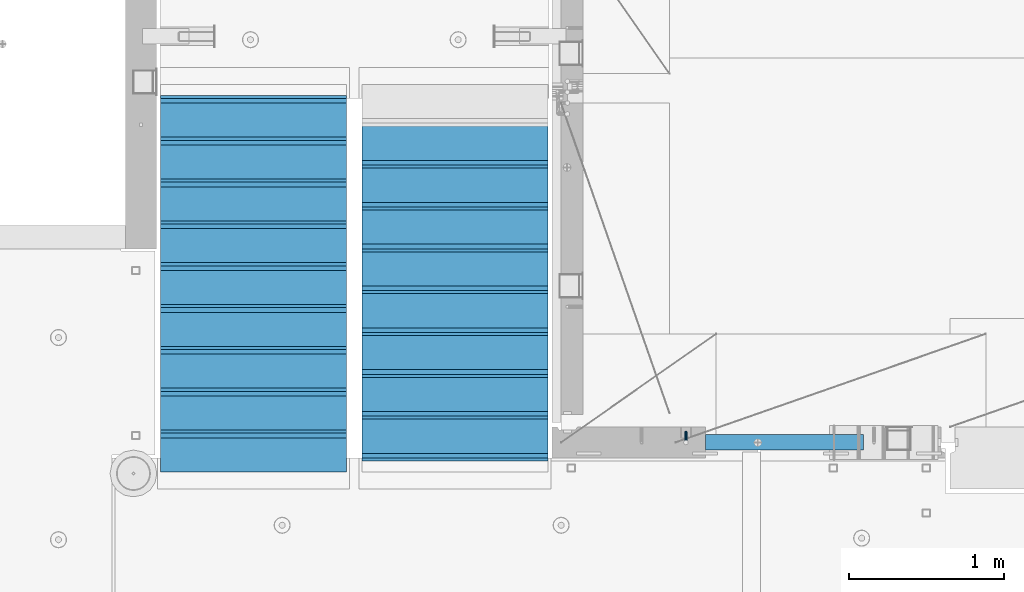
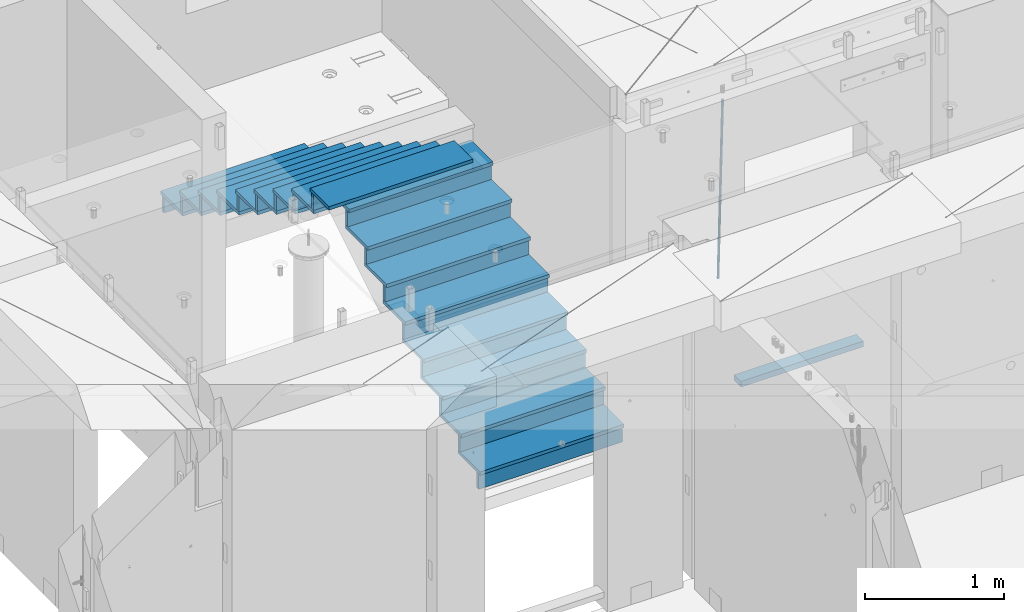
# One storey, part 103 of 325: 36 beams, 3 elements without a shape of their own.
"""IFC2X3 building model written with IfcOpenShell, lengths in millimetres."""

from ifc_helpers import new_model, si_unit, frame, origin_with_axes, place, context, subcontext, project, spatial, faceted_brep, material, type_object, element, aggregate, save


model = new_model("IFC2X3")

# Units and contexts
model_context = context("Model", 3, precision=1e-05, world=origin_with_axes())
body_context = subcontext(model_context, "Body", "Model", "MODEL_VIEW")
ifc_project = project(units=[si_unit("LENGTHUNIT", "METRE", prefix="MILLI"), si_unit("AREAUNIT", "SQUARE_METRE"), si_unit("VOLUMEUNIT", "CUBIC_METRE"), si_unit("MASSUNIT", "GRAM", prefix="KILO"), si_unit("TIMEUNIT", "SECOND"), si_unit("PLANEANGLEUNIT", "RADIAN"), si_unit("SOLIDANGLEUNIT", "STERADIAN"), si_unit("THERMODYNAMICTEMPERATUREUNIT", "DEGREE_CELSIUS"), si_unit("LUMINOUSINTENSITYUNIT", "LUMEN")], contexts=[model_context])

# Site, building, storey
site_placement = place(None, origin_with_axes())
site = spatial("IfcSite", under=ifc_project, at=site_placement, CompositionType="ELEMENT")
building_placement = place(site_placement, origin_with_axes())
building = spatial("IfcBuilding", under=site, at=building_placement, CompositionType="ELEMENT")
storey_placement = place(building_placement, origin_with_axes())
storey = spatial("IfcBuildingStorey", under=building, at=storey_placement, Name="1", CompositionType="ELEMENT", Elevation=0.0)

# Assembly, beams
assembly_1_placement = place(storey_placement, origin_with_axes())
assembly_1 = element("IfcElementAssembly", 1, at=assembly_1_placement, inside=storey, AssemblyPlace="NOTDEFINED", PredefinedType="REINFORCEMENT_UNIT")
ifc_material_1 = material()
beam_type_1 = type_object("IfcBeamType", Name="D20", PredefinedType="NOTDEFINED")
beam_1_placement = place(assembly_1_placement, frame((23075.0006866416, 17045.0000022791, 82790.0), z_axis=(0.00020576299992186, -0.999642804629538, -0.0267249099901004), x_axis=(-4.30000201928125e-08, -0.0267249099948059, 0.999642825806181)))
beam_1 = element("IfcBeam", 2, at=beam_1_placement, type_object=beam_type_1, material=ifc_material_1, Name="JM20", ObjectType="D20", context=body_context, shape_type="Brep", body=[
    faceted_brep([(0.0, -10.0, 0.0), (-4.19531716033816e-08, -7.07106781186667, -7.07106781187031), (60.4266690400545, -7.0710677960451, -7.07106780570757), (60.4266690441291, -9.99999998418934, 6.15546014159918e-09), (0.0, 0.0, -10.0), (60.426669036824, 1.58106558956206e-08, -9.99999999384454), (4.196772351861e-08, 7.07106781186303, -7.07106781186667), (60.4266690363438, 7.07106782768096, -7.07106780570757), (0.0, 10.0, 0.0), (60.4266690388904, 10.0000000158179, 6.15182216279209e-09), (4.196772351861e-08, 7.07106781185939, 7.07106781185939), (60.4266690429649, 7.07106782768096, 7.07106781802577), (0.0, 0.0, 10.0), (60.4266690461809, 1.58179318532348e-08, 10.0000000061555), (-4.19531716033816e-08, -7.07106781187031, 7.07106781185939), (60.4266690466611, -7.07106779605238, 7.07106781802213), (61.0378400410118, -7.07106779588503, -7.07106780564936), (60.991799419251, -9.99999998403655, 6.21366780251265e-09), (61.0569027789461, 1.5985278878361e-08, -9.99999999378269), (61.0378209396877, 7.07106782784831, -7.07106780564936), (60.9917724058905, 10.0000000159635, 6.21366780251265e-09), (60.9457317841297, 7.07106782781193, 7.0710678180767), (60.9266690461809, 1.59488990902901e-08, 10.0000000062028), (60.9457508854539, -7.07106779591413, 7.0710678180767), (61.6489592143771, -7.07106614513759, -7.06310863441468), (61.5568818710308, -9.9999984576425, 0.00735959856683621), (61.6870830769039, 1.71821739058942e-06, -9.99179257185824), (61.6489210170112, 7.07106947854481, -7.06310888312146), (61.556827851804, 10.0000015422847, 0.00735924683976918), (61.4647505084577, 7.07106922979438, 7.07782747982128), (61.4266266459163, 1.36643211590126e-06, 10.0065114172685), (61.464788705809, -7.07106639389531, 7.07782772852806), (176.543135720174, -7.07075579406956, -5.56673531796696), (176.451058376813, -9.99968810657447, 1.50373291501455), (176.581259582701, 0.000312069292704109, -8.49541925541052), (176.543097522794, 7.07137982961285, -5.56673556667374), (176.451004357587, 10.00031189336, 1.50373256329476), (176.35892701424, 7.07137958085514, 8.57420079627263), (176.320803151699, 0.000311717507429421, 11.5028847337162), (176.358965211621, -7.07075604281999, 8.57420104497578), (177.098753836006, -7.07075429323595, -5.55949898843028), (176.98362511232, -9.99968666800123, 1.510669025065), (177.146421932586, 0.000313595905026887, -8.48805862247536), (177.098706077581, 7.07138133041735, -5.55949936166144), (176.983557571715, 10.0003133318824, 1.51066849724157), (176.868428848029, 7.07138095712435, 8.58083651073321), (176.820760751449, 0.000313067976094317, 11.5093961447819), (176.868476606425, -7.07075466652896, 8.58083688396073), (177.654312950661, -7.07075204110879, -5.54863964998367), (177.516135294456, -9.99968450931192, 1.52107783331303), (177.711524267797, 0.000315886711177882, -8.47701274570863), (177.654255632195, 7.07138358250813, -5.54864021007961), (177.516054233929, 10.0003154905207, 1.5210770412159), (177.377876577739, 7.0713830223176, 8.59079452451624), (177.320665260588, 0.000315094497636892, 11.5191676202448), (177.377933896176, -7.07075260129932, 8.59079508461218), (299.580241614967, -7.07025777803938, -3.16539205229128), (299.442063958748, -9.99919024624614, 3.90432543100542), (299.637452932104, 0.000810149780591019, -6.09376514801625), (299.58018429653, 7.07187784557391, -3.16539261238358), (299.441982898265, 10.0008097535901, 3.90432463891557), (299.303805242045, 7.07187728538338, 10.974042122205), (299.246593924894, 0.00080935756341205, 13.9024152179336), (299.303862560482, -7.07025833822991, 10.9740426822973), (300.088882651282, -7.07025571611666, -3.15544980669438), (299.971788958996, -9.99918809853989, 3.91467979818117), (300.137357441272, 0.000812176291219657, -6.0839936725497), (300.088834180511, 7.07187990754028, -3.15545019384081), (299.971753863239, 10.0008119014747, 3.91467990454839), (299.854660170953, 7.07187951844026, 10.9848095094276), (299.806185380992, 0.000811626032373169, 13.9133533752902), (299.854708641738, -7.07025610520941, 10.9848098965813), (300.597573977022, -7.07025429077839, -3.14854421417112), (300.501599787152, -9.99918661431002, 3.92187219230618), (300.637311376035, 0.00081357714952901, -6.07720669196715), (300.597534354776, 7.07188133290401, -3.14854448120241), (300.501543752835, 10.0008133856099, 3.92187181466215), (300.40556956298, 7.07188106207104, 10.9922882211395), (300.365832163967, 0.000813194146758178, 13.9209506989318), (300.405609185211, -7.07025456160045, 10.9922884881707), (1494.60304651056, -7.06690872122999, 13.060333041718), (1494.50707232069, -9.99584104476162, 20.1307494481916), (1494.64278390956, 0.00415914670156781, 10.1316705639183), (1494.6030068883, 7.07522690244878, 13.0603327746867), (1494.50701628637, 10.004158955162, 20.1307490705476), (1494.4110420965, 7.07522663162308, 27.2011654770249), (1494.3713046975, 0.00415876370243495, 30.1298279548209), (1494.41108171875, -7.06690899205205, 27.2011657440526), (1495.1211563645, -7.06690726950183, 13.067366492749), (1495.00702625545, -9.99583964390331, 20.1375364287742), (1495.20660775043, 0.00416072652296862, 10.1393245920117), (1495.21332415029, 7.07522861253892, 13.0686179608165), (1495.13737118813, 10.0041607213934, 20.1393062718889), (1495.02324107911, 7.07522834699193, 27.2094762079141), (1494.93778969315, 0.00416035097441636, 30.1375181086514), (1494.93107329329, -7.06690753504881, 27.2082247398503), (1495.63922435709, -7.07365070849846, 13.0742491942874), (1495.5069397148, -10.00235861486, 20.1441724282631), (1495.77038591086, -0.00317370150150964, 10.1468279224828), (1495.82359171678, 7.06728286786529, 13.0767522910828), (1495.76767453534, 9.99594143344802, 20.1477123416917), (1495.63538989302, 7.0672335270865, 27.2176355756565), (1495.50422833927, -0.00324347991045215, 30.1450568474684), (1495.45102253335, -7.07370004928453, 27.2151324788683), (1517.48046966468, -7.35846502584536, 13.3649345949125), (1517.34818502239, -10.2871729322142, 20.4348578288809), (1517.61163121845, -0.287988018848409, 10.4375133231042), (1517.66483702436, 6.78246855052203, 13.3674376917079), (1517.60891984291, 9.71112711610476, 20.4383977423167), (1517.47663520063, 6.78241920973232, 27.5083209762815), (1517.34547364687, -0.288057797257352, 30.4357422480862), (1517.29226784095, -7.35851436663143, 27.5058178794898), (1518.11590717161, -7.36675126123009, 13.3733916404526), (1518.00827439407, -10.295780632965, 20.4436429663911), (1518.18994308249, -0.295529324139352, 10.4452100827657), (1518.18701289421, 6.77565927010801, 13.3743873367348), (1518.10883307132, 9.70460814510079, 20.4450510935785), (1518.00120029377, 6.77557877335857, 27.515302419517), (1517.9271643829, -0.295643163732166, 30.4434839772002), (1517.93009457119, -7.36683175797953, 27.5143067232275), (1518.75139849893, -7.36487536471395, 13.3816537936873), (1518.66841952164, -10.2938120781764, 20.4522328350286), (1518.76830418318, -0.293831718903675, 10.452712053142), (1518.7092334538, 6.77719739167878, 13.3811419616068), (1518.60878914295, 9.7060990139762, 20.4515089951637), (1518.52581016565, 6.77716230052101, 27.522088036505), (1518.50890448141, -0.293881345296541, 30.4510297770539), (1518.56797521077, -7.36491045587172, 27.5225998685855), (1618.77218426704, -7.06661321754655, 14.6790318180938), (1618.68920528975, -9.99554993101265, 21.7496108594387), (1618.78908995127, 0.0044304282637313, 11.7500900775485), (1618.73001922191, 7.07545953884255, 14.6785199860096), (1618.62957491104, 10.0043611611436, 21.748887019563), (1618.54659593375, 7.07542444768478, 28.8194660609042), (1618.52969024952, 0.00438080187086598, 31.7484078014531), (1618.58876097888, -7.06664830870795, 28.819977892992)], [[[0, 1, 2, 3]], [[1, 4, 5, 2]], [[4, 6, 7, 5]], [[6, 8, 9, 7]], [[8, 10, 11, 9]], [[10, 12, 13, 11]], [[12, 14, 15, 13]], [[14, 0, 3, 15]], [[14, 12, 10, 8, 6, 4, 1, 0]], [[3, 2, 16, 17]], [[2, 5, 18, 16]], [[5, 7, 19, 18]], [[7, 9, 20, 19]], [[9, 11, 21, 20]], [[11, 13, 22, 21]], [[13, 15, 23, 22]], [[15, 3, 17, 23]], [[17, 16, 24, 25]], [[16, 18, 26, 24]], [[18, 19, 27, 26]], [[19, 20, 28, 27]], [[20, 21, 29, 28]], [[21, 22, 30, 29]], [[22, 23, 31, 30]], [[23, 17, 25, 31]], [[25, 24, 32, 33]], [[24, 26, 34, 32]], [[26, 27, 35, 34]], [[27, 28, 36, 35]], [[28, 29, 37, 36]], [[29, 30, 38, 37]], [[30, 31, 39, 38]], [[31, 25, 33, 39]], [[33, 32, 40, 41]], [[32, 34, 42, 40]], [[34, 35, 43, 42]], [[35, 36, 44, 43]], [[36, 37, 45, 44]], [[37, 38, 46, 45]], [[38, 39, 47, 46]], [[39, 33, 41, 47]], [[41, 40, 48, 49]], [[40, 42, 50, 48]], [[42, 43, 51, 50]], [[43, 44, 52, 51]], [[44, 45, 53, 52]], [[45, 46, 54, 53]], [[46, 47, 55, 54]], [[47, 41, 49, 55]], [[49, 48, 56, 57]], [[48, 50, 58, 56]], [[50, 51, 59, 58]], [[51, 52, 60, 59]], [[52, 53, 61, 60]], [[53, 54, 62, 61]], [[54, 55, 63, 62]], [[55, 49, 57, 63]], [[57, 56, 64, 65]], [[56, 58, 66, 64]], [[58, 59, 67, 66]], [[59, 60, 68, 67]], [[60, 61, 69, 68]], [[61, 62, 70, 69]], [[62, 63, 71, 70]], [[63, 57, 65, 71]], [[65, 64, 72, 73]], [[64, 66, 74, 72]], [[66, 67, 75, 74]], [[67, 68, 76, 75]], [[68, 69, 77, 76]], [[69, 70, 78, 77]], [[70, 71, 79, 78]], [[71, 65, 73, 79]], [[73, 72, 80, 81]], [[72, 74, 82, 80]], [[74, 75, 83, 82]], [[75, 76, 84, 83]], [[76, 77, 85, 84]], [[77, 78, 86, 85]], [[78, 79, 87, 86]], [[79, 73, 81, 87]], [[81, 80, 88, 89]], [[80, 82, 90, 88]], [[82, 83, 91, 90]], [[83, 84, 92, 91]], [[84, 85, 93, 92]], [[85, 86, 94, 93]], [[86, 87, 95, 94]], [[87, 81, 89, 95]], [[89, 88, 96, 97]], [[88, 90, 98, 96]], [[90, 91, 99, 98]], [[91, 92, 100, 99]], [[92, 93, 101, 100]], [[93, 94, 102, 101]], [[94, 95, 103, 102]], [[95, 89, 97, 103]], [[97, 96, 104, 105]], [[96, 98, 106, 104]], [[98, 99, 107, 106]], [[99, 100, 108, 107]], [[100, 101, 109, 108]], [[101, 102, 110, 109]], [[102, 103, 111, 110]], [[103, 97, 105, 111]], [[105, 104, 112, 113]], [[104, 106, 114, 112]], [[106, 107, 115, 114]], [[107, 108, 116, 115]], [[108, 109, 117, 116]], [[109, 110, 118, 117]], [[110, 111, 119, 118]], [[111, 105, 113, 119]], [[113, 112, 120, 121]], [[112, 114, 122, 120]], [[114, 115, 123, 122]], [[115, 116, 124, 123]], [[116, 117, 125, 124]], [[117, 118, 126, 125]], [[118, 119, 127, 126]], [[119, 113, 121, 127]], [[121, 120, 128, 129]], [[120, 122, 130, 128]], [[122, 123, 131, 130]], [[123, 124, 132, 131]], [[124, 125, 133, 132]], [[125, 126, 134, 133]], [[126, 127, 135, 134]], [[127, 121, 129, 135]], [[130, 131, 132, 133, 134, 135, 129, 128]]]),
])
ifc_material_2 = material(Name="TIMBER/T24")
beam_type_2 = type_object("IfcBeamType", PredefinedType="NOTDEFINED")
beam_2_placement = place(assembly_1_placement, frame((23200.0006866455, 16980.0, 81880.0), z_axis=(0.0, 0.0, 1.0), x_axis=(1.0, 0.0, 0.0)))
beam_2 = element("IfcBeam", 3, at=beam_2_placement, type_object=beam_type_2, material=ifc_material_2, context=body_context, shape_type="Brep", body=[
    faceted_brep([(0.0, 50.0, -25.0), (0.0, 50.0, 25.0), (1020.0, 50.0, 25.0), (1020.0, 50.0, -25.0), (0.0, -50.0, 25.0), (1020.0, -50.0, 25.0), (0.0, -50.0, -25.0), (1020.0, -50.0, -25.0)], [[[0, 1, 2, 3]], [[1, 4, 5, 2]], [[4, 6, 7, 5]], [[6, 0, 3, 7]], [[5, 7, 3, 2]], [[6, 4, 1, 0]]]),
])
aggregate(assembly_1, [beam_1, beam_2])

assembly_2_placement = place(storey_placement, origin_with_axes())
assembly_2 = element("IfcElementAssembly", 4, at=assembly_2_placement, inside=storey, Name="E9", AssemblyPlace="NOTDEFINED", PredefinedType="NOTDEFINED")
ifc_material_3 = material(Name="Undefined/C32/40")
beam_type_3 = type_object("IfcBeamType", PredefinedType="NOTDEFINED")
beam_3_placement = place(assembly_2_placement, frame((20885.0002457424, 17024.9998138874, 84662.1), z_axis=(0.0, 1.0, 0.0), x_axis=(-1.0, 3.00000001838171e-08, 0.0)))
beam_3 = element("IfcBeam", 5, at=beam_3_placement, type_object=beam_type_3, material=ifc_material_3, Name="E9", context=body_context, shape_type="Brep", body=[
    faceted_brep([(0.0, 68.5, -15.0), (0.0, 68.5, 15.0), (1200.0, 68.5, 15.0), (1200.0, 68.5, -15.0), (0.0, -68.5, 15.0), (1200.0, -68.5, 15.0), (0.0, -68.5, -15.0), (1200.0, -68.5, -15.0)], [[[0, 1, 2, 3]], [[1, 4, 5, 2]], [[4, 6, 7, 5]], [[6, 0, 3, 7]], [[5, 7, 3, 2]], [[6, 4, 1, 0]]]),
])
beam_4_placement = place(assembly_2_placement, frame((20885.0002457424, 17294.9998138874, 84495.4), z_axis=(0.0, 1.0, 0.0), x_axis=(-1.0, 3.00000001838171e-08, 0.0)))
beam_4 = element("IfcBeam", 6, at=beam_4_placement, type_object=beam_type_3, material=ifc_material_3, Name="E9", context=body_context, shape_type="Brep", body=[
    faceted_brep([(0.0, 68.5, -15.0), (0.0, 68.5, 15.0), (1200.0, 68.5, 15.0), (1200.0, 68.5, -15.0), (0.0, -68.5, 15.0), (1200.0, -68.5, 15.0), (0.0, -68.5, -15.0), (1200.0, -68.5, -15.0)], [[[0, 1, 2, 3]], [[1, 4, 5, 2]], [[4, 6, 7, 5]], [[6, 0, 3, 7]], [[5, 7, 3, 2]], [[6, 4, 1, 0]]]),
])
beam_5_placement = place(assembly_2_placement, frame((20885.0002457424, 17564.9998138874, 84328.7), z_axis=(0.0, 1.0, 0.0), x_axis=(-1.0, 3.00000001838171e-08, 0.0)))
beam_5 = element("IfcBeam", 7, at=beam_5_placement, type_object=beam_type_3, material=ifc_material_3, Name="E9", context=body_context, shape_type="Brep", body=[
    faceted_brep([(0.0, 68.5, -15.0), (0.0, 68.5, 15.0), (1200.0, 68.5, 15.0), (1200.0, 68.5, -15.0), (0.0, -68.5, 15.0), (1200.0, -68.5, 15.0), (0.0, -68.5, -15.0), (1200.0, -68.5, -15.0)], [[[0, 1, 2, 3]], [[1, 4, 5, 2]], [[4, 6, 7, 5]], [[6, 0, 3, 7]], [[5, 7, 3, 2]], [[6, 4, 1, 0]]]),
])
beam_6_placement = place(assembly_2_placement, frame((20885.0002457424, 17834.9998138874, 84162.0), z_axis=(0.0, 1.0, 0.0), x_axis=(-1.0, 3.00000001838171e-08, 0.0)))
beam_6 = element("IfcBeam", 8, at=beam_6_placement, type_object=beam_type_3, material=ifc_material_3, Name="E9", context=body_context, shape_type="Brep", body=[
    faceted_brep([(0.0, 68.5, -15.0), (0.0, 68.5, 15.0), (1200.0, 68.5, 15.0), (1200.0, 68.5, -15.0), (0.0, -68.5, 15.0), (1200.0, -68.5, 15.0), (0.0, -68.5, -15.0), (1200.0, -68.5, -15.0)], [[[0, 1, 2, 3]], [[1, 4, 5, 2]], [[4, 6, 7, 5]], [[6, 0, 3, 7]], [[5, 7, 3, 2]], [[6, 4, 1, 0]]]),
])
beam_7_placement = place(assembly_2_placement, frame((20885.0002457424, 18104.9998138874, 83995.3), z_axis=(0.0, 1.0, 0.0), x_axis=(-1.0, 3.00000001838171e-08, 0.0)))
beam_7 = element("IfcBeam", 9, at=beam_7_placement, type_object=beam_type_3, material=ifc_material_3, Name="E9", context=body_context, shape_type="Brep", body=[
    faceted_brep([(0.0, 68.5, -15.0), (0.0, 68.5, 15.0), (1200.0, 68.5, 15.0), (1200.0, 68.5, -15.0), (0.0, -68.5, 15.0), (1200.0, -68.5, 15.0), (0.0, -68.5, -15.0), (1200.0, -68.5, -15.0)], [[[0, 1, 2, 3]], [[1, 4, 5, 2]], [[4, 6, 7, 5]], [[6, 0, 3, 7]], [[5, 7, 3, 2]], [[6, 4, 1, 0]]]),
])
beam_8_placement = place(assembly_2_placement, frame((20885.0002457424, 18374.9998138874, 83828.6), z_axis=(0.0, 1.0, 0.0), x_axis=(-1.0, 3.00000001838171e-08, 0.0)))
beam_8 = element("IfcBeam", 10, at=beam_8_placement, type_object=beam_type_3, material=ifc_material_3, Name="E9", context=body_context, shape_type="Brep", body=[
    faceted_brep([(0.0, 68.5, -15.0), (0.0, 68.5, 15.0), (1200.0, 68.5, 15.0), (1200.0, 68.5, -15.0), (0.0, -68.5, 15.0), (1200.0, -68.5, 15.0), (0.0, -68.5, -15.0), (1200.0, -68.5, -15.0)], [[[0, 1, 2, 3]], [[1, 4, 5, 2]], [[4, 6, 7, 5]], [[6, 0, 3, 7]], [[5, 7, 3, 2]], [[6, 4, 1, 0]]]),
])
beam_9_placement = place(assembly_2_placement, frame((20885.0002457424, 18644.9998138874, 83661.9), z_axis=(0.0, 1.0, 0.0), x_axis=(-1.0, 3.00000001838171e-08, 0.0)))
beam_9 = element("IfcBeam", 11, at=beam_9_placement, type_object=beam_type_3, material=ifc_material_3, Name="E9", context=body_context, shape_type="Brep", body=[
    faceted_brep([(0.0, 68.5, -15.0), (0.0, 68.5, 15.0), (1200.0, 68.5, 15.0), (1200.0, 68.5, -15.0), (0.0, -68.5, 15.0), (1200.0, -68.5, 15.0), (0.0, -68.5, -15.0), (1200.0, -68.5, -15.0)], [[[0, 1, 2, 3]], [[1, 4, 5, 2]], [[4, 6, 7, 5]], [[6, 0, 3, 7]], [[5, 7, 3, 2]], [[6, 4, 1, 0]]]),
])
beam_10_placement = place(assembly_2_placement, frame((20885.0002457424, 18914.9998138874, 83495.2), z_axis=(0.0, 1.0, 0.0), x_axis=(-1.0, 3.00000001838171e-08, 0.0)))
beam_10 = element("IfcBeam", 12, at=beam_10_placement, type_object=beam_type_3, material=ifc_material_3, Name="E9", context=body_context, shape_type="Brep", body=[
    faceted_brep([(0.0, 68.5, -15.0), (0.0, 68.5, 15.0), (1200.0, 68.5, 15.0), (1200.0, 68.5, -15.0), (0.0, -68.5, 15.0), (1200.0, -68.5, 15.0), (0.0, -68.5, -15.0), (1200.0, -68.5, -15.0)], [[[0, 1, 2, 3]], [[1, 4, 5, 2]], [[4, 6, 7, 5]], [[6, 0, 3, 7]], [[5, 7, 3, 2]], [[6, 4, 1, 0]]]),
])
beam_11_placement = place(assembly_2_placement, frame((20885.0002457424, 19184.9998138874, 83328.5), z_axis=(0.0, 1.0, 0.0), x_axis=(-1.0, 3.00000001838171e-08, 0.0)))
beam_11 = element("IfcBeam", 13, at=beam_11_placement, type_object=beam_type_3, material=ifc_material_3, Name="E9", context=body_context, shape_type="Brep", body=[
    faceted_brep([(0.0, 68.5, -15.0), (0.0, 68.5, 15.0), (1200.0, 68.5, 15.0), (1200.0, 68.5, -15.0), (0.0, -68.5, 15.0), (1200.0, -68.5, 15.0), (0.0, -68.5, -15.0), (1200.0, -68.5, -15.0)], [[[0, 1, 2, 3]], [[1, 4, 5, 2]], [[4, 6, 7, 5]], [[6, 0, 3, 7]], [[5, 7, 3, 2]], [[6, 4, 1, 0]]]),
])

assembly_3_placement = place(storey_placement, origin_with_axes())
assembly_3 = element("IfcElementAssembly", 14, at=assembly_3_placement, inside=storey, Name="E9", AssemblyPlace="NOTDEFINED", PredefinedType="NOTDEFINED")
beam_12_placement = place(assembly_3_placement, frame((20985.002175553, 18785.001025346, 82995.1036072969), z_axis=(0.0, -1.0, 0.0), x_axis=(1.0, 0.0, 0.0)))
beam_12 = element("IfcBeam", 15, at=beam_12_placement, type_object=beam_type_3, material=ifc_material_3, Name="E9", context=body_context, shape_type="Brep", body=[
    faceted_brep([(0.0, 68.5, -15.0), (0.0, 68.5, 15.0), (1200.0, 68.5, 15.0), (1200.0, 68.5, -15.0), (0.0, -68.5, 15.0), (1200.0, -68.5, 15.0), (0.0, -68.5, -15.0), (1200.0, -68.5, -15.0)], [[[0, 1, 2, 3]], [[1, 4, 5, 2]], [[4, 6, 7, 5]], [[6, 0, 3, 7]], [[5, 7, 3, 2]], [[6, 4, 1, 0]]]),
])
beam_13_placement = place(assembly_3_placement, frame((20985.002175553, 18515.001025346, 82828.4036072969), z_axis=(0.0, -1.0, 0.0), x_axis=(1.0, 0.0, 0.0)))
beam_13 = element("IfcBeam", 16, at=beam_13_placement, type_object=beam_type_3, material=ifc_material_3, Name="E9", context=body_context, shape_type="Brep", body=[
    faceted_brep([(0.0, 68.5, -15.0), (0.0, 68.5, 15.0), (1200.0, 68.5, 15.0), (1200.0, 68.5, -15.0), (0.0, -68.5, 15.0), (1200.0, -68.5, 15.0), (0.0, -68.5, -15.0), (1200.0, -68.5, -15.0)], [[[0, 1, 2, 3]], [[1, 4, 5, 2]], [[4, 6, 7, 5]], [[6, 0, 3, 7]], [[5, 7, 3, 2]], [[6, 4, 1, 0]]]),
])
beam_14_placement = place(assembly_3_placement, frame((20985.002175553, 18245.001025346, 82661.7036072969), z_axis=(0.0, -1.0, 0.0), x_axis=(1.0, 0.0, 0.0)))
beam_14 = element("IfcBeam", 17, at=beam_14_placement, type_object=beam_type_3, material=ifc_material_3, Name="E9", context=body_context, shape_type="Brep", body=[
    faceted_brep([(0.0, 68.5, -15.0), (0.0, 68.5, 15.0), (1200.0, 68.5, 15.0), (1200.0, 68.5, -15.0), (0.0, -68.5, 15.0), (1200.0, -68.5, 15.0), (0.0, -68.5, -15.0), (1200.0, -68.5, -15.0)], [[[0, 1, 2, 3]], [[1, 4, 5, 2]], [[4, 6, 7, 5]], [[6, 0, 3, 7]], [[5, 7, 3, 2]], [[6, 4, 1, 0]]]),
])
beam_15_placement = place(assembly_3_placement, frame((20985.002175553, 17975.001025346, 82495.0036072969), z_axis=(0.0, -1.0, 0.0), x_axis=(1.0, 0.0, 0.0)))
beam_15 = element("IfcBeam", 18, at=beam_15_placement, type_object=beam_type_3, material=ifc_material_3, Name="E9", context=body_context, shape_type="Brep", body=[
    faceted_brep([(0.0, 68.5, -15.0), (0.0, 68.5, 15.0), (1200.0, 68.5, 15.0), (1200.0, 68.5, -15.0), (0.0, -68.5, 15.0), (1200.0, -68.5, 15.0), (0.0, -68.5, -15.0), (1200.0, -68.5, -15.0)], [[[0, 1, 2, 3]], [[1, 4, 5, 2]], [[4, 6, 7, 5]], [[6, 0, 3, 7]], [[5, 7, 3, 2]], [[6, 4, 1, 0]]]),
])
beam_16_placement = place(assembly_3_placement, frame((20985.002175553, 17705.001025346, 82328.3036072969), z_axis=(0.0, -1.0, 0.0), x_axis=(1.0, 0.0, 0.0)))
beam_16 = element("IfcBeam", 19, at=beam_16_placement, type_object=beam_type_3, material=ifc_material_3, Name="E9", context=body_context, shape_type="Brep", body=[
    faceted_brep([(0.0, 68.5, -15.0), (0.0, 68.5, 15.0), (1200.0, 68.5, 15.0), (1200.0, 68.5, -15.0), (0.0, -68.5, 15.0), (1200.0, -68.5, 15.0), (0.0, -68.5, -15.0), (1200.0, -68.5, -15.0)], [[[0, 1, 2, 3]], [[1, 4, 5, 2]], [[4, 6, 7, 5]], [[6, 0, 3, 7]], [[5, 7, 3, 2]], [[6, 4, 1, 0]]]),
])
beam_17_placement = place(assembly_3_placement, frame((20985.002175553, 17435.001025346, 82161.6036072969), z_axis=(0.0, -1.0, 0.0), x_axis=(1.0, 0.0, 0.0)))
beam_17 = element("IfcBeam", 20, at=beam_17_placement, type_object=beam_type_3, material=ifc_material_3, Name="E9", context=body_context, shape_type="Brep", body=[
    faceted_brep([(0.0, 68.5, -15.0), (0.0, 68.5, 15.0), (1200.0, 68.5, 15.0), (1200.0, 68.5, -15.0), (0.0, -68.5, 15.0), (1200.0, -68.5, 15.0), (0.0, -68.5, -15.0), (1200.0, -68.5, -15.0)], [[[0, 1, 2, 3]], [[1, 4, 5, 2]], [[4, 6, 7, 5]], [[6, 0, 3, 7]], [[5, 7, 3, 2]], [[6, 4, 1, 0]]]),
])
beam_18_placement = place(assembly_3_placement, frame((20985.002175553, 17165.001025346, 81994.9036072969), z_axis=(0.0, -1.0, 0.0), x_axis=(1.0, 0.0, 0.0)))
beam_18 = element("IfcBeam", 21, at=beam_18_placement, type_object=beam_type_3, material=ifc_material_3, Name="E9", context=body_context, shape_type="Brep", body=[
    faceted_brep([(0.0, 68.5, -15.0), (0.0, 68.5, 15.0), (1200.0, 68.5, 15.0), (1200.0, 68.5, -15.0), (0.0, -68.5, 15.0), (1200.0, -68.5, 15.0), (0.0, -68.5, -15.0), (1200.0, -68.5, -15.0)], [[[0, 1, 2, 3]], [[1, 4, 5, 2]], [[4, 6, 7, 5]], [[6, 0, 3, 7]], [[5, 7, 3, 2]], [[6, 4, 1, 0]]]),
])
beam_19_placement = place(assembly_3_placement, frame((20985.002175553, 16895.001025346, 81828.2036072969), z_axis=(0.0, -1.0, 0.0), x_axis=(1.0, 0.0, 0.0)))
beam_19 = element("IfcBeam", 22, at=beam_19_placement, type_object=beam_type_3, material=ifc_material_3, Name="E9", context=body_context, shape_type="Brep", body=[
    faceted_brep([(0.0, 68.5, -15.0), (0.0, 68.5, 15.0), (1200.0, 68.5, 15.0), (1200.0, 68.5, -15.0), (0.0, -68.5, 15.0), (1200.0, -68.5, 15.0), (0.0, -68.5, -15.0), (1200.0, -68.5, -15.0)], [[[0, 1, 2, 3]], [[1, 4, 5, 2]], [[4, 6, 7, 5]], [[6, 0, 3, 7]], [[5, 7, 3, 2]], [[6, 4, 1, 0]]]),
])

# Beam
beam_type_4 = type_object("IfcBeamType", PredefinedType="NOTDEFINED")
beam_20_placement = place(assembly_2_placement, frame((20885.0002457424, 17169.9998138874, 84578.6), z_axis=(0.0, 1.0, 0.0), x_axis=(-1.0, 3.00000001838171e-08, 0.0)))
beam_20 = element("IfcBeam", 23, at=beam_20_placement, type_object=beam_type_4, material=ifc_material_3, Name="E9", context=body_context, shape_type="Brep", body=[
    faceted_brep([(0.0, 15.0, -160.0), (0.0, 15.0, 160.0), (1200.0, 15.0, 160.0), (1200.0, 15.0, -160.0), (0.0, -15.0, 160.0), (1200.0, -15.0, 160.0), (0.0, -15.0, -160.0), (1200.0, -15.0, -160.0)], [[[0, 1, 2, 3]], [[1, 4, 5, 2]], [[4, 6, 7, 5]], [[6, 0, 3, 7]], [[5, 7, 3, 2]], [[6, 4, 1, 0]]]),
])

beam_21_placement = place(assembly_2_placement, frame((20885.0002457424, 17439.9998138874, 84411.9), z_axis=(0.0, 1.0, 0.0), x_axis=(-1.0, 3.00000001838171e-08, 0.0)))
beam_21 = element("IfcBeam", 24, at=beam_21_placement, type_object=beam_type_4, material=ifc_material_3, Name="E9", context=body_context, shape_type="Brep", body=[
    faceted_brep([(0.0, 15.0, -160.0), (0.0, 15.0, 160.0), (1200.0, 15.0, 160.0), (1200.0, 15.0, -160.0), (0.0, -15.0, 160.0), (1200.0, -15.0, 160.0), (0.0, -15.0, -160.0), (1200.0, -15.0, -160.0)], [[[0, 1, 2, 3]], [[1, 4, 5, 2]], [[4, 6, 7, 5]], [[6, 0, 3, 7]], [[5, 7, 3, 2]], [[6, 4, 1, 0]]]),
])

beam_22_placement = place(assembly_2_placement, frame((20885.0002457424, 17709.9998138874, 84245.2), z_axis=(0.0, 1.0, 0.0), x_axis=(-1.0, 3.00000001838171e-08, 0.0)))
beam_22 = element("IfcBeam", 25, at=beam_22_placement, type_object=beam_type_4, material=ifc_material_3, Name="E9", context=body_context, shape_type="Brep", body=[
    faceted_brep([(0.0, 15.0, -160.0), (0.0, 15.0, 160.0), (1200.0, 15.0, 160.0), (1200.0, 15.0, -160.0), (0.0, -15.0, 160.0), (1200.0, -15.0, 160.0), (0.0, -15.0, -160.0), (1200.0, -15.0, -160.0)], [[[0, 1, 2, 3]], [[1, 4, 5, 2]], [[4, 6, 7, 5]], [[6, 0, 3, 7]], [[5, 7, 3, 2]], [[6, 4, 1, 0]]]),
])

beam_23_placement = place(assembly_2_placement, frame((20885.0002457424, 17979.9998138874, 84078.5), z_axis=(0.0, 1.0, 0.0), x_axis=(-1.0, 3.00000001838171e-08, 0.0)))
beam_23 = element("IfcBeam", 26, at=beam_23_placement, type_object=beam_type_4, material=ifc_material_3, Name="E9", context=body_context, shape_type="Brep", body=[
    faceted_brep([(0.0, 15.0, -160.0), (0.0, 15.0, 160.0), (1200.0, 15.0, 160.0), (1200.0, 15.0, -160.0), (0.0, -15.0, 160.0), (1200.0, -15.0, 160.0), (0.0, -15.0, -160.0), (1200.0, -15.0, -160.0)], [[[0, 1, 2, 3]], [[1, 4, 5, 2]], [[4, 6, 7, 5]], [[6, 0, 3, 7]], [[5, 7, 3, 2]], [[6, 4, 1, 0]]]),
])

beam_24_placement = place(assembly_2_placement, frame((20885.0002457424, 18249.9998138874, 83911.8), z_axis=(0.0, 1.0, 0.0), x_axis=(-1.0, 3.00000001838171e-08, 0.0)))
beam_24 = element("IfcBeam", 27, at=beam_24_placement, type_object=beam_type_4, material=ifc_material_3, Name="E9", context=body_context, shape_type="Brep", body=[
    faceted_brep([(0.0, 15.0, -160.0), (0.0, 15.0, 160.0), (1200.0, 15.0, 160.0), (1200.0, 15.0, -160.0), (0.0, -15.0, 160.0), (1200.0, -15.0, 160.0), (0.0, -15.0, -160.0), (1200.0, -15.0, -160.0)], [[[0, 1, 2, 3]], [[1, 4, 5, 2]], [[4, 6, 7, 5]], [[6, 0, 3, 7]], [[5, 7, 3, 2]], [[6, 4, 1, 0]]]),
])

beam_25_placement = place(assembly_2_placement, frame((20885.0002457424, 18519.9998138874, 83745.1), z_axis=(0.0, 1.0, 0.0), x_axis=(-1.0, 3.00000001838171e-08, 0.0)))
beam_25 = element("IfcBeam", 28, at=beam_25_placement, type_object=beam_type_4, material=ifc_material_3, Name="E9", context=body_context, shape_type="Brep", body=[
    faceted_brep([(0.0, 15.0, -160.0), (0.0, 15.0, 160.0), (1200.0, 15.0, 160.0), (1200.0, 15.0, -160.0), (0.0, -15.0, 160.0), (1200.0, -15.0, 160.0), (0.0, -15.0, -160.0), (1200.0, -15.0, -160.0)], [[[0, 1, 2, 3]], [[1, 4, 5, 2]], [[4, 6, 7, 5]], [[6, 0, 3, 7]], [[5, 7, 3, 2]], [[6, 4, 1, 0]]]),
])

beam_26_placement = place(assembly_2_placement, frame((20885.0002457424, 18789.9998138874, 83578.4), z_axis=(0.0, 1.0, 0.0), x_axis=(-1.0, 3.00000001838171e-08, 0.0)))
beam_26 = element("IfcBeam", 29, at=beam_26_placement, type_object=beam_type_4, material=ifc_material_3, Name="E9", context=body_context, shape_type="Brep", body=[
    faceted_brep([(0.0, 15.0, -160.0), (0.0, 15.0, 160.0), (1200.0, 15.0, 160.0), (1200.0, 15.0, -160.0), (0.0, -15.0, 160.0), (1200.0, -15.0, 160.0), (0.0, -15.0, -160.0), (1200.0, -15.0, -160.0)], [[[0, 1, 2, 3]], [[1, 4, 5, 2]], [[4, 6, 7, 5]], [[6, 0, 3, 7]], [[5, 7, 3, 2]], [[6, 4, 1, 0]]]),
])

beam_27_placement = place(assembly_2_placement, frame((20885.0002457424, 19059.9998138874, 83411.7), z_axis=(0.0, 1.0, 0.0), x_axis=(-1.0, 3.00000001838171e-08, 0.0)))
beam_27 = element("IfcBeam", 30, at=beam_27_placement, type_object=beam_type_4, material=ifc_material_3, Name="E9", context=body_context, shape_type="Brep", body=[
    faceted_brep([(0.0, 15.0, -160.0), (0.0, 15.0, 160.0), (1200.0, 15.0, 160.0), (1200.0, 15.0, -160.0), (0.0, -15.0, 160.0), (1200.0, -15.0, 160.0), (0.0, -15.0, -160.0), (1200.0, -15.0, -160.0)], [[[0, 1, 2, 3]], [[1, 4, 5, 2]], [[4, 6, 7, 5]], [[6, 0, 3, 7]], [[5, 7, 3, 2]], [[6, 4, 1, 0]]]),
])

beam_28_placement = place(assembly_3_placement, frame((20985.002175553, 18910.001025346, 83078.303607297), z_axis=(0.0, -1.0, 0.0), x_axis=(1.0, 0.0, 0.0)))
beam_28 = element("IfcBeam", 31, at=beam_28_placement, type_object=beam_type_4, material=ifc_material_3, Name="E9", context=body_context, shape_type="Brep", body=[
    faceted_brep([(0.0, 15.0, -160.0), (0.0, 15.0, 160.0), (1200.0, 15.0, 160.0), (1200.0, 15.0, -160.0), (0.0, -15.0, 160.0), (1200.0, -15.0, 160.0), (0.0, -15.0, -160.0), (1200.0, -15.0, -160.0)], [[[0, 1, 2, 3]], [[1, 4, 5, 2]], [[4, 6, 7, 5]], [[6, 0, 3, 7]], [[5, 7, 3, 2]], [[6, 4, 1, 0]]]),
])

beam_29_placement = place(assembly_3_placement, frame((20985.002175553, 18640.001025346, 82911.6036072969), z_axis=(0.0, -1.0, 0.0), x_axis=(1.0, 0.0, 0.0)))
beam_29 = element("IfcBeam", 32, at=beam_29_placement, type_object=beam_type_4, material=ifc_material_3, Name="E9", context=body_context, shape_type="Brep", body=[
    faceted_brep([(0.0, 15.0, -160.0), (0.0, 15.0, 160.0), (1200.0, 15.0, 160.0), (1200.0, 15.0, -160.0), (0.0, -15.0, 160.0), (1200.0, -15.0, 160.0), (0.0, -15.0, -160.0), (1200.0, -15.0, -160.0)], [[[0, 1, 2, 3]], [[1, 4, 5, 2]], [[4, 6, 7, 5]], [[6, 0, 3, 7]], [[5, 7, 3, 2]], [[6, 4, 1, 0]]]),
])

beam_30_placement = place(assembly_3_placement, frame((20985.002175553, 18370.001025346, 82744.9036072969), z_axis=(0.0, -1.0, 0.0), x_axis=(1.0, 0.0, 0.0)))
beam_30 = element("IfcBeam", 33, at=beam_30_placement, type_object=beam_type_4, material=ifc_material_3, Name="E9", context=body_context, shape_type="Brep", body=[
    faceted_brep([(0.0, 15.0, -160.0), (0.0, 15.0, 160.0), (1200.0, 15.0, 160.0), (1200.0, 15.0, -160.0), (0.0, -15.0, 160.0), (1200.0, -15.0, 160.0), (0.0, -15.0, -160.0), (1200.0, -15.0, -160.0)], [[[0, 1, 2, 3]], [[1, 4, 5, 2]], [[4, 6, 7, 5]], [[6, 0, 3, 7]], [[5, 7, 3, 2]], [[6, 4, 1, 0]]]),
])

beam_31_placement = place(assembly_3_placement, frame((20985.002175553, 18100.001025346, 82578.2036072969), z_axis=(0.0, -1.0, 0.0), x_axis=(1.0, 0.0, 0.0)))
beam_31 = element("IfcBeam", 34, at=beam_31_placement, type_object=beam_type_4, material=ifc_material_3, Name="E9", context=body_context, shape_type="Brep", body=[
    faceted_brep([(0.0, 15.0, -160.0), (0.0, 15.0, 160.0), (1200.0, 15.0, 160.0), (1200.0, 15.0, -160.0), (0.0, -15.0, 160.0), (1200.0, -15.0, 160.0), (0.0, -15.0, -160.0), (1200.0, -15.0, -160.0)], [[[0, 1, 2, 3]], [[1, 4, 5, 2]], [[4, 6, 7, 5]], [[6, 0, 3, 7]], [[5, 7, 3, 2]], [[6, 4, 1, 0]]]),
])

beam_32_placement = place(assembly_3_placement, frame((20985.002175553, 17830.001025346, 82411.5036072969), z_axis=(0.0, -1.0, 0.0), x_axis=(1.0, 0.0, 0.0)))
beam_32 = element("IfcBeam", 35, at=beam_32_placement, type_object=beam_type_4, material=ifc_material_3, Name="E9", context=body_context, shape_type="Brep", body=[
    faceted_brep([(0.0, 15.0, -160.0), (0.0, 15.0, 160.0), (1200.0, 15.0, 160.0), (1200.0, 15.0, -160.0), (0.0, -15.0, 160.0), (1200.0, -15.0, 160.0), (0.0, -15.0, -160.0), (1200.0, -15.0, -160.0)], [[[0, 1, 2, 3]], [[1, 4, 5, 2]], [[4, 6, 7, 5]], [[6, 0, 3, 7]], [[5, 7, 3, 2]], [[6, 4, 1, 0]]]),
])

beam_33_placement = place(assembly_3_placement, frame((20985.002175553, 17560.001025346, 82244.8036072969), z_axis=(0.0, -1.0, 0.0), x_axis=(1.0, 0.0, 0.0)))
beam_33 = element("IfcBeam", 36, at=beam_33_placement, type_object=beam_type_4, material=ifc_material_3, Name="E9", context=body_context, shape_type="Brep", body=[
    faceted_brep([(0.0, 15.0, -160.0), (0.0, 15.0, 160.0), (1200.0, 15.0, 160.0), (1200.0, 15.0, -160.0), (0.0, -15.0, 160.0), (1200.0, -15.0, 160.0), (0.0, -15.0, -160.0), (1200.0, -15.0, -160.0)], [[[0, 1, 2, 3]], [[1, 4, 5, 2]], [[4, 6, 7, 5]], [[6, 0, 3, 7]], [[5, 7, 3, 2]], [[6, 4, 1, 0]]]),
])

beam_34_placement = place(assembly_3_placement, frame((20985.002175553, 17290.001025346, 82078.1036072969), z_axis=(0.0, -1.0, 0.0), x_axis=(1.0, 0.0, 0.0)))
beam_34 = element("IfcBeam", 37, at=beam_34_placement, type_object=beam_type_4, material=ifc_material_3, Name="E9", context=body_context, shape_type="Brep", body=[
    faceted_brep([(0.0, 15.0, -160.0), (0.0, 15.0, 160.0), (1200.0, 15.0, 160.0), (1200.0, 15.0, -160.0), (0.0, -15.0, 160.0), (1200.0, -15.0, 160.0), (0.0, -15.0, -160.0), (1200.0, -15.0, -160.0)], [[[0, 1, 2, 3]], [[1, 4, 5, 2]], [[4, 6, 7, 5]], [[6, 0, 3, 7]], [[5, 7, 3, 2]], [[6, 4, 1, 0]]]),
])

beam_35_placement = place(assembly_3_placement, frame((20985.002175553, 17020.001025346, 81911.4036072969), z_axis=(0.0, -1.0, 0.0), x_axis=(1.0, 0.0, 0.0)))
beam_35 = element("IfcBeam", 38, at=beam_35_placement, type_object=beam_type_4, material=ifc_material_3, Name="E9", context=body_context, shape_type="Brep", body=[
    faceted_brep([(0.0, 15.0, -160.0), (0.0, 15.0, 160.0), (1200.0, 15.0, 160.0), (1200.0, 15.0, -160.0), (0.0, -15.0, 160.0), (1200.0, -15.0, 160.0), (0.0, -15.0, -160.0), (1200.0, -15.0, -160.0)], [[[0, 1, 2, 3]], [[1, 4, 5, 2]], [[4, 6, 7, 5]], [[6, 0, 3, 7]], [[5, 7, 3, 2]], [[6, 4, 1, 0]]]),
])

aggregate(assembly_3, [beam_28, beam_12, beam_29, beam_13, beam_30, beam_14, beam_31, beam_15, beam_32, beam_16, beam_33, beam_17, beam_34, beam_18, beam_35, beam_19])

beam_type_5 = type_object("IfcBeamType", PredefinedType="NOTDEFINED")
beam_36_placement = place(assembly_2_placement, frame((20885.0002457424, 16924.9998138874, 84745.3), z_axis=(0.0, 1.0, 0.0), x_axis=(-1.0, 3.00000001838171e-08, 0.0)))
beam_36 = element("IfcBeam", 39, at=beam_36_placement, type_object=beam_type_5, material=ifc_material_3, Name="E9", context=body_context, shape_type="Brep", body=[
    faceted_brep([(0.0, 15.0, -135.0), (0.0, 15.0, 135.0), (1200.0, 15.0, 135.0), (1200.0, 15.0, -135.0), (0.0, -15.0, 135.0), (1200.0, -15.0, 135.0), (0.0, -15.0, -135.0), (1200.0, -15.0, -135.0)], [[[0, 1, 2, 3]], [[1, 4, 5, 2]], [[4, 6, 7, 5]], [[6, 0, 3, 7]], [[5, 7, 3, 2]], [[6, 4, 1, 0]]]),
])

aggregate(assembly_2, [beam_3, beam_20, beam_4, beam_21, beam_5, beam_22, beam_6, beam_23, beam_7, beam_24, beam_8, beam_25, beam_9, beam_26, beam_10, beam_27, beam_36, beam_11])

save(model, "model.ifc")
